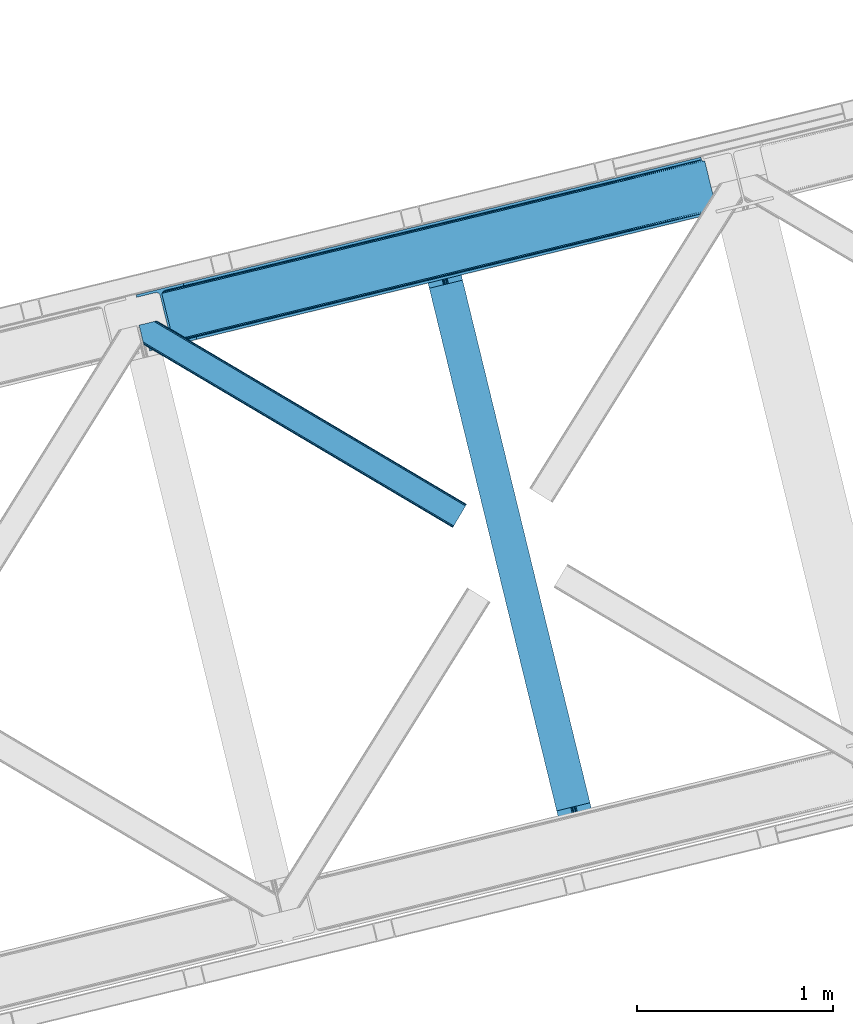
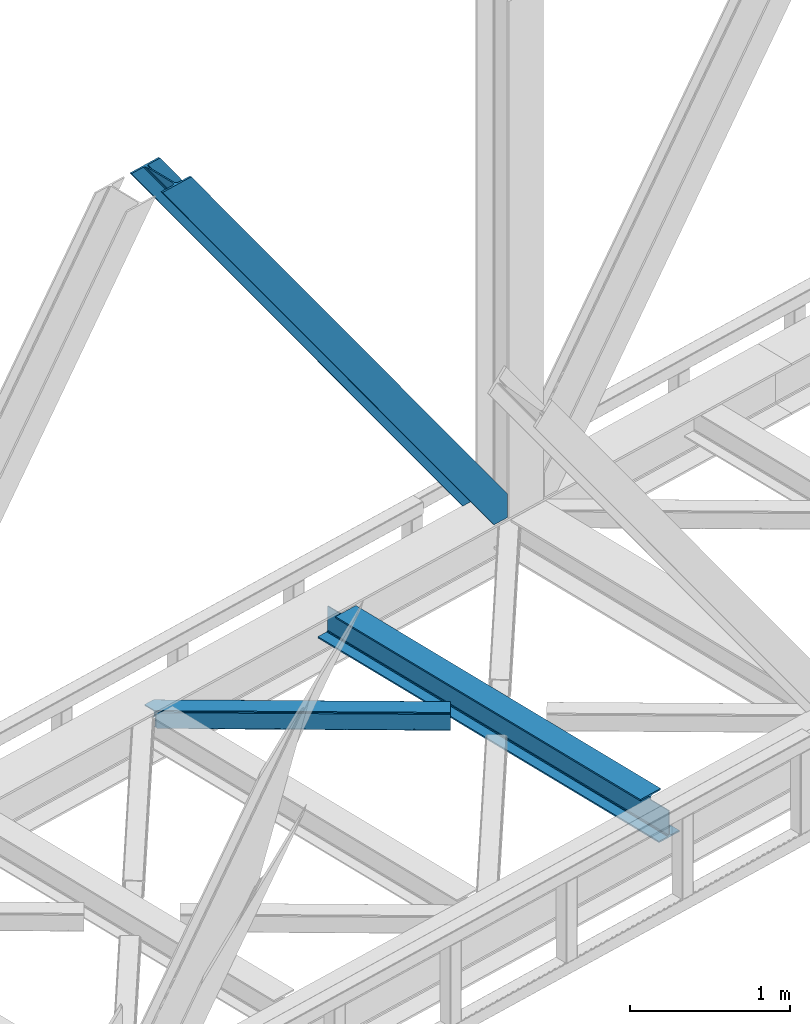
# One storey, part 61 of 92: 2 members, 1 beam.
"""IFC4 building model written with IfcOpenShell, lengths in millimetres."""

from ifc_helpers import new_model, entity, si_unit, converted_unit, derived_unit, direction, frame, origin, place, context, subcontext, project, spatial, triangles, polygons, material, type_object, element, save


model = new_model("IFC4")

# Units and contexts
model_context = context("Model", 3, precision=0.01, world=origin(), true_north=direction((6.12303176911189e-17, 1.0)))
plan_context = context("Plan", 3, precision=0.01, world=origin(), true_north=direction((6.12303176911189e-17, 1.0)))
body_context = subcontext(model_context, "Body", "Model", "MODEL_VIEW")
ifc_project = project(units=[si_unit("LENGTHUNIT", "METRE", prefix="MILLI"), si_unit("AREAUNIT", "SQUARE_METRE"), si_unit("VOLUMEUNIT", "CUBIC_METRE"), converted_unit("PLANEANGLEUNIT", "DEGREE", entity("IfcRatioMeasure", 0.0174532925199433), si_unit("PLANEANGLEUNIT", "RADIAN"), dimensions=[0, 0, 0, 0, 0, 0, 0]), si_unit("MASSUNIT", "GRAM", prefix="KILO"), derived_unit("MASSDENSITYUNIT", [(si_unit("MASSUNIT", "GRAM", prefix="KILO"), 1), (si_unit("LENGTHUNIT", "METRE"), -3)]), derived_unit("MOMENTOFINERTIAUNIT", [(si_unit("LENGTHUNIT", "METRE"), 4)]), si_unit("TIMEUNIT", "SECOND"), si_unit("FREQUENCYUNIT", "HERTZ"), si_unit("THERMODYNAMICTEMPERATUREUNIT", "DEGREE_CELSIUS"), derived_unit("THERMALTRANSMITTANCEUNIT", [(si_unit("MASSUNIT", "GRAM", prefix="KILO"), 1), (si_unit("THERMODYNAMICTEMPERATUREUNIT", "KELVIN"), -1), (si_unit("TIMEUNIT", "SECOND"), -3)]), derived_unit("VOLUMETRICFLOWRATEUNIT", [(si_unit("LENGTHUNIT", "METRE"), 3), (si_unit("TIMEUNIT", "SECOND"), -1)]), derived_unit("MASSFLOWRATEUNIT", [(si_unit("MASSUNIT", "GRAM", prefix="KILO"), 1), (si_unit("TIMEUNIT", "SECOND"), -1)]), derived_unit("ROTATIONALFREQUENCYUNIT", [(si_unit("TIMEUNIT", "SECOND"), -1)]), si_unit("ELECTRICCURRENTUNIT", "AMPERE"), si_unit("ELECTRICVOLTAGEUNIT", "VOLT"), si_unit("POWERUNIT", "WATT"), si_unit("FORCEUNIT", "NEWTON", prefix="KILO"), si_unit("ILLUMINANCEUNIT", "LUX"), si_unit("LUMINOUSFLUXUNIT", "LUMEN"), si_unit("LUMINOUSINTENSITYUNIT", "CANDELA"), derived_unit("USERDEFINED", [(si_unit("MASSUNIT", "GRAM", prefix="KILO"), -1), (si_unit("LENGTHUNIT", "METRE"), -2), (si_unit("TIMEUNIT", "SECOND"), 3), (si_unit("LUMINOUSFLUXUNIT", "LUMEN"), 1)]), derived_unit("LINEARVELOCITYUNIT", [(si_unit("LENGTHUNIT", "METRE"), 1), (si_unit("TIMEUNIT", "SECOND"), -1)]), si_unit("PRESSUREUNIT", "PASCAL"), derived_unit("USERDEFINED", [(si_unit("LENGTHUNIT", "METRE"), -2), (si_unit("MASSUNIT", "GRAM", prefix="KILO"), 1), (si_unit("TIMEUNIT", "SECOND"), -2)]), derived_unit("LINEARFORCEUNIT", [(si_unit("MASSUNIT", "GRAM", prefix="KILO"), 1), (si_unit("LENGTHUNIT", "METRE"), 1), (si_unit("TIMEUNIT", "SECOND"), -2), (si_unit("LENGTHUNIT", "METRE"), -1)]), derived_unit("PLANARFORCEUNIT", [(si_unit("MASSUNIT", "GRAM", prefix="KILO"), 1), (si_unit("LENGTHUNIT", "METRE"), 1), (si_unit("TIMEUNIT", "SECOND"), -2), (si_unit("LENGTHUNIT", "METRE"), -2)])], contexts=[model_context, plan_context])

# Site, building, storey
site_placement = place(None, origin())
site = spatial("IfcSite", under=ifc_project, at=site_placement, CompositionType="ELEMENT")
building_placement = place(site_placement, origin())
building = spatial("IfcBuilding", under=site, at=building_placement, CompositionType="ELEMENT")
storey_placement = place(building_placement, frame((0.0, 0.0, 15900.0)))
storey = spatial("IfcBuildingStorey", under=building, at=storey_placement, Name="05", CompositionType="ELEMENT", Elevation=15900.0)

# Beam
ifc_material = material(Name="Metal painted (White)")
beam_type = type_object("IfcBeamType", PredefinedType="BEAM")
beam_placement = place(storey_placement, frame((-25639.15, 11536.37, 3441.0)))
element("IfcBeam", 1, at=beam_placement, inside=storey, type_object=beam_type, material=ifc_material, ObjectType="Steel Beam", PredefinedType="BEAM", context=body_context, shape_type="Tessellation", body=[
    polygons([(898.85391135252, 41.4445662733125, 11.000000000004), (898.85391135252, 41.4445662733103, 2.16573425859679e-12), (170.021610174757, 3031.3960252037, 2.16573425859679e-12), (170.021610174757, 3031.3960252037, 11.000000000004), (832.788371398898, 25.3403919499699, 11.000000000004), (103.956070221131, 3015.29185088035, 11.000000000004), (826.839621377601, 23.8903211957417, 12.217927479826), (98.007320199834, 3013.84178012613, 12.217927479826), (821.796514621497, 22.6610105689216, 15.6862915010192), (92.964213443734, 3012.61246949931, 15.6862915010192), (818.426818418321, 21.8396114687162, 20.8770650821657), (89.5945172405625, 3011.7910703991, 20.8770650821657), (817.243538468639, 21.5511744621227, 27.0000000000047), (88.4112372908766, 3011.50263339251, 27.0000000000047), (81.6103728838801, 3009.84485074157, 27.0000000000047), (81.6103728838801, 3009.84485074157, 203.000000000006), (88.4112372908766, 3011.50263339251, 203.000000000006), (0.0, 2989.95145893039, 2.16573425859679e-12), (0.0, 2989.95145893039, 10.9999999999997), (66.0655399536172, 3006.05563325373, 11.000000000004), (72.014289974914, 3007.50570400796, 12.2179274798217), (77.057396731014, 3008.73501463478, 15.6862915010192), (80.4270929341986, 3009.55641373499, 20.8770650821657), (817.243538468639, 21.5511744621227, 203.000000000006), (810.442674061647, 19.8933918111897, 203.000000000006), (810.442674061647, 19.8933918111897, 27.0000000000047), (809.259394111961, 19.6049548046006, 20.8770650821657), (805.889697908777, 18.7835557043887, 15.6862915010192), (800.846591152677, 17.5542450775707, 12.2179274798217), (794.89784113138, 16.1041743233447, 11.000000000004), (728.832301177763, 2.16573425859679e-12, 10.9999999999997), (728.832301177763, 2.16573425859679e-12, 2.16573425859679e-12), (777.543778045845, 184.415062601696, 203.069791966819), (125.888966506592, 2857.75452019163, 203.000000000006), (126.111847295742, 2856.8401777572, 203.617301946336), (126.124761540265, 2856.78719778431, 217.000003693143), (777.398574796912, 185.010597404074, 217.000003676718), (777.39944540481, 185.007025963197, 204.00000679514), (770.833476881408, 182.385463974447, 203.006342981529), (770.610629219861, 183.299815969778, 203.617301946336), (770.597714975342, 183.352795942671, 217.000003693143), (119.323901718691, 2855.1293963229, 217.000003676718), (119.323031110798, 2855.13296776378, 204.00000679514), (119.178731521747, 2855.72494066435, 203.076120467494), (119.088102099599, 2856.09673754069, 203.000000000006), (778.582059520948, 185.298194377516, 223.122939328039), (781.951055929627, 186.122464201395, 228.313710402595), (786.993691333638, 187.353708426701, 231.782072735464), (792.942270204354, 188.804481281383, 232.999999602236), (859.007721069869, 204.909021065317, 232.999999283132), (859.006247733431, 204.91506504219, 243.999994005812), (688.984866829519, 163.4695582453, 243.999994827032), (688.986340165957, 163.463514268429, 233.000000104353), (755.05179103148, 179.568054052363, 232.999999785253), (761.00069615981, 181.017488520586, 231.782072861012), (766.044260666937, 182.244921343719, 228.313710479427), (769.414647576681, 183.06348700115, 223.12293937232), (118.140416994651, 2854.84179934946, 223.122939328039), (114.771420585976, 2854.01752952557, 228.313710402599), (109.728785181961, 2852.78628530027, 231.782072735464), (103.780206311245, 2851.33551244559, 232.999999602236), (37.7147554457299, 2835.23097266165, 232.999999283128), (37.7162287821674, 2835.22492868478, 243.999994005812), (207.73760968608, 2876.67043548167, 243.999994827032), (207.736136349642, 2876.67647945855, 233.000000104357), (141.670685484119, 2860.57193967461, 232.999999785253), (135.721780355789, 2859.12250520638, 231.782072861012), (130.678215848667, 2857.89507238325, 228.313710479427), (127.307828938918, 2857.07650672582, 223.12293937232)], [[[1, 2, 3, 4]], [[5, 1, 4, 6]], [[7, 5, 6, 8]], [[9, 7, 8, 10]], [[11, 9, 10, 12]], [[13, 11, 12, 14]], [[15, 16, 17, 14, 12, 10, 8, 6, 4, 3, 18, 19, 20, 21, 22, 23]], [[13, 24, 25, 26, 27, 28, 29, 30, 31, 32, 2, 1, 5, 7, 9, 11]], [[2, 32, 18, 3]], [[32, 31, 19, 18]], [[31, 30, 20, 19]], [[27, 26, 15, 23]], [[28, 27, 23, 22]], [[29, 28, 22, 21]], [[30, 29, 21, 20]], [[33, 24, 13, 14, 17, 34, 35, 36, 37, 38]], [[25, 39, 40, 41, 42, 43, 44, 16, 15, 26]], [[39, 25, 24, 33]], [[45, 34, 17, 16]], [[41, 40, 38, 37, 46, 47, 48, 49, 50, 51, 52, 53, 54, 55, 56, 57]], [[42, 58, 59, 60, 61, 62, 63, 64, 65, 66, 67, 68, 69, 36, 35, 43]], [[46, 37, 36, 69]], [[47, 46, 69, 68]], [[48, 47, 68, 67]], [[49, 48, 67, 66]], [[50, 49, 66, 65]], [[51, 50, 65, 64]], [[52, 51, 64, 63]], [[53, 52, 63, 62]], [[54, 53, 62, 61]], [[55, 54, 61, 60]], [[56, 55, 60, 59]], [[57, 56, 59, 58]], [[41, 57, 58, 42]]], closed=False),
])

# Members
member_type_1 = type_object("IfcMemberType", PredefinedType="BRACE")
member_1_placement = place(storey_placement, frame((-27100.53, 14051.52, 3695.0)))
element("IfcMember", 2, at=member_1_placement, inside=storey, type_object=member_type_1, ObjectType="Steel Vertical Brace", PredefinedType="BRACE", context=body_context, shape_type="Tessellation", body=[
    triangles([(2966.89332275391, 730.999566650391, 0.80925292968459), (2967.55142211914, 730.015905761718, 1.10690917968532), (2966.08174438477, 729.657788085939, 0.0), (2964.18651123047, 737.429406738282, 0.0), (2962.43545532227, 728.768307495118, 8.31577148437282), (2962.43545532227, 728.768307495118, 0.0), (2505.85634765625, 612.606793212892, 658.855133056641), (2511.3606628418, 609.931375122071, 662.301434326171), (2954.04294433594, 717.839904785156, 38.6743835449197), (2954.17084350586, 719.764205932617, 32.1678039550752), (2501.41243286133, 617.533236694337, 656.552947998047), (2958.54266967774, 726.957952880859, 14.8293273925774), (2955.07311401367, 722.241961669923, 26.1867736816384), (2955.64052124024, 723.796517944336, 22.4381652832017), (655.166986083987, 156.054428100586, 3289.34108276367), (649.437103271484, 156.068380737304, 3285.27854003906), (213.879968261721, 48.4865753173835, 3911.00081176758), (205.268865966798, 47.7982452392571, 3911.00081176758), (643.935113525393, 158.743798828125, 3281.83223876953), (197.318188476565, 49.8760253906257, 3911.00081176758), (639.491198730469, 163.67024230957, 3279.53005371094), (191.241815185549, 54.4048187255867, 3911.00081176758), (636.784387207033, 170.100082397461, 3278.7231262207), (187.960620117188, 60.6951324462898, 3911.00081176758), (2954.16154174805, 716.45859375, 50.6410949707024), (2517.08822021485, 609.918585205078, 666.36397705078), (2051.60965576172, 496.452255249023, 1322.10767211914), (2045.87977294922, 496.466207885742, 1318.04512939453), (1586.12876586914, 382.987088012695, 1977.85369262695), (1580.39888305664, 382.999877929688, 1973.78882446289), (1120.64787597656, 269.52075805664, 2633.59738769531), (1114.91799316406, 269.534710693359, 2629.53251953125), (2040.37545776367, 499.140463256836, 1314.598828125), (1574.89689331055, 385.675296020509, 1970.34484863281), (1109.41600341797, 272.208966064452, 2626.08854370117), (2035.93154296875, 504.068069458008, 1312.29896850586), (1570.45065307617, 390.601739501953, 1968.04266357422), (1104.9697631836, 277.136572265625, 2623.78635864258), (2498.70562133789, 623.964239501953, 655.74602050781), (2033.22473144531, 510.497909545898, 1311.48971557617), (1567.74384155274, 397.03274230957, 1967.23341064453), (1102.26527709961, 283.566412353515, 2622.97710571289), (2909.00615844727, 963.801635742188, 0.0), (2443.52526855469, 850.335305786133, 655.74602050781), (1978.04437866211, 736.870138549804, 1311.48971557617), (1512.56348876953, 623.40380859375, 1967.23341064453), (1047.08259887695, 509.937478637696, 2622.97710571289), (581.604034423828, 396.472311401367, 3278.7231262207), (132.780267333987, 287.067361450196, 3911.00081176758), (307.43239746094, 71.2909973144524, 3911.00081176758), (2954.16154174805, 716.45859375, 182.433050537107), (2954.35222778321, 715.476095581054, 0.0), (2954.17084350586, 719.764205932617, 0.0), (2954.35222778321, 715.476095581054, 182.495837402341), (2955.64052124024, 723.796517944336, 0.0), (2958.54266967774, 726.957952880859, 0.0), (2957.19624023438, 703.817504882813, 182.495837402341), (310.511279296876, 58.6603729248054, 3911.00081176758), (2957.19624023438, 703.817504882813, 0.0), (2846.09139404297, 676.735437011719, 0.0), (69.8655029296897, 0.0, 3911.00081176758), (2843.01251220703, 689.364898681641, 0.0), (66.78662109375, 12.6306243896488, 3911.00081176758), (160.336724853518, 35.4350463867195, 3911.00081176758), (2936.56494140625, 712.169320678711, 0.0), (2953.95922851563, 734.936535644532, 0.0), (2953.940625, 727.842782592774, 0.0), (177.733337402344, 58.2022613525387, 3911.00081176758), (177.714733886722, 51.1073455810547, 3911.00081176758), (2950.62919921875, 721.024594116212, 0.0), (174.403308105469, 44.2903198242184, 3911.00081176758), (2944.52724609375, 715.520278930664, 0.0), (168.301354980471, 38.7860046386722, 3911.00081176758), (2898.77887573242, 961.307601928711, 0.0), (122.552984619142, 284.573327636719, 3911.00081176758), (2872.85720214844, 973.517321777344, 0.0), (2881.46830444336, 974.205651855469, 0.0), (105.244738769532, 297.471377563477, 3911.00081176758), (96.6289855957039, 296.781884765625, 3911.00081176758), (2889.4189819336, 972.127871704102, 0.0), (113.193090820314, 295.393597412109, 3911.00081176758), (2895.49768066406, 967.599078369141, 0.0), (119.271789550781, 290.864804077148, 3911.00081176758), (3.07888183593968, 273.978625488282, 3911.00081176758), (2779.30477294922, 950.712899780274, 0.0), (2776.22589111328, 963.342361450195, 0.0), (0.0, 286.608087158203, 3911.00081176758), (142.212249755859, 306.482455444337, 3911.00081176758), (150.174554443362, 309.834576416015, 3911.00081176758), (136.110296630861, 300.979302978516, 3911.00081176758), (132.798870849612, 294.161114501952, 3911.00081176758), (240.648101806641, 345.268460083007, 3911.00081176758), (243.72698364258, 332.638998413086, 3911.00081176758), (2887.33073730469, 990.425592041016, 182.495837402341), (2887.33073730469, 990.425592041016, 0.0), (2890.45612792969, 977.806594848633, 182.433050537107), (2890.17242431641, 978.767001342774, 182.495837402341), (1522.42102661133, 644.333926391602, 1977.85369262695), (591.461572265627, 417.402429199219, 3289.34108276367), (1056.9424621582, 530.867596435546, 2633.59738769531), (1987.90191650391, 757.800256347657, 1322.10767211914), (2453.38280639649, 871.265423583985, 666.36397705078), (2890.45612792969, 977.806594848633, 50.6410949707024), (2890.17242431641, 978.767001342774, 0.0), (2890.986328125, 976.525277709961, 38.6743835449197), (2892.14672241211, 974.999789428712, 33.1630920410134), (2891.98394165039, 974.87537841797, 0.0), (2893.56524047852, 973.138275146484, 26.4425720214822), (2895.14421386719, 971.973229980469, 22.4381652832017), (2903.46463623047, 970.684936523438, 8.31577148437282), (2903.46463623047, 970.684936523438, 0.0), (2899.17652587891, 970.50122680664, 0.0), (2899.17652587891, 970.50122680664, 14.8293273925774), (2895.14421386719, 971.973229980469, 0.0), (2907.11092529297, 971.573254394532, 0.0), (2444.64845581055, 863.710070800782, 658.855133056641), (2442.96948852539, 857.29069519043, 656.552947998047), (2908.45037841797, 970.755862426759, 0.80925292968459), (2908.5829284668, 971.932534790039, 1.10690917968532), (581.048254394533, 403.426538085938, 3279.53005371094), (582.724896240237, 409.847076416016, 3281.83223876953), (586.380487060549, 414.753753662109, 3285.27854003906), (2448.30404663086, 868.616748046876, 662.301434326171), (1977.48859863282, 743.824365234375, 1312.29896850586), (1512.00770874024, 630.358035278321, 1968.04266357422), (1046.52681884766, 516.892868041992, 2623.78635864258), (1979.16756591797, 750.243740844728, 1314.598828125), (1513.68667602539, 636.778573608399, 1970.34484863281), (1048.20578613281, 523.312243652344, 2626.08854370117), (1982.82315673828, 755.151580810547, 1318.04512939453), (1517.34226684571, 641.685250854493, 1973.78882446289), (1051.86137695313, 528.218920898438, 2629.53251953125)], [[1, 2, 3], [3, 4, 1], [2, 5, 6], [6, 3, 2], [7, 8, 9], [9, 10, 7], [11, 12, 5], [5, 1, 11], [11, 7, 13], [13, 14, 11], [14, 12, 11], [15, 16, 17], [18, 17, 16], [16, 19, 18], [20, 18, 19], [19, 21, 20], [22, 20, 21], [21, 23, 22], [24, 22, 23], [5, 2, 1], [10, 13, 7], [25, 9, 8], [8, 26, 25], [26, 8, 27], [28, 27, 8], [27, 28, 29], [30, 29, 28], [29, 30, 31], [32, 31, 30], [31, 32, 15], [16, 15, 32], [8, 7, 33], [33, 28, 8], [28, 33, 34], [34, 30, 28], [30, 34, 35], [35, 32, 30], [32, 35, 16], [19, 16, 35], [7, 11, 36], [36, 33, 7], [33, 36, 37], [37, 34, 33], [34, 37, 38], [38, 35, 34], [35, 38, 21], [21, 19, 35], [1, 4, 11], [39, 11, 4], [11, 39, 36], [40, 36, 39], [36, 40, 37], [41, 37, 40], [37, 41, 42], [42, 38, 37], [38, 42, 23], [23, 21, 38], [4, 43, 44], [45, 39, 44], [41, 40, 45], [41, 45, 46], [44, 39, 4], [45, 40, 39], [42, 41, 46], [46, 47, 42], [47, 48, 23], [49, 24, 48], [47, 23, 42], [48, 24, 23], [50, 51, 29], [29, 31, 50], [31, 15, 50], [17, 50, 15], [27, 29, 51], [51, 25, 26], [26, 27, 51], [52, 9, 25], [52, 53, 10], [10, 9, 52], [25, 51, 54], [54, 52, 25], [14, 53, 55], [53, 14, 13], [10, 53, 13], [56, 12, 55], [14, 55, 12], [6, 5, 56], [12, 56, 5], [57, 54, 58], [54, 51, 50], [50, 58, 54], [57, 59, 52], [52, 54, 57], [58, 60, 57], [58, 61, 60], [60, 59, 57], [62, 60, 63], [61, 63, 60], [63, 64, 62], [65, 62, 64], [66, 67, 68], [69, 68, 67], [67, 70, 69], [71, 69, 70], [70, 72, 71], [73, 71, 72], [72, 65, 73], [64, 73, 65], [74, 66, 75], [68, 75, 66], [76, 77, 78], [78, 79, 76], [77, 80, 81], [81, 78, 77], [80, 82, 83], [83, 81, 80], [82, 74, 75], [75, 83, 82], [79, 84, 85], [85, 76, 79], [86, 85, 87], [84, 87, 85], [75, 68, 49], [71, 73, 18], [64, 61, 17], [63, 61, 64], [73, 64, 17], [68, 69, 22], [69, 71, 20], [81, 88, 78], [87, 79, 89], [79, 78, 89], [87, 84, 79], [81, 83, 90], [83, 75, 91], [49, 68, 24], [17, 18, 73], [22, 69, 20], [18, 20, 71], [22, 24, 68], [58, 17, 61], [58, 50, 17], [89, 78, 88], [90, 83, 91], [49, 91, 75], [90, 88, 81], [89, 92, 87], [92, 89, 93], [92, 86, 87], [86, 92, 94], [95, 86, 94], [96, 97, 93], [97, 94, 92], [92, 93, 97], [98, 96, 93], [93, 99, 100], [99, 93, 89], [100, 98, 93], [96, 98, 101], [101, 102, 96], [103, 96, 102], [97, 104, 94], [95, 94, 104], [104, 105, 106], [96, 103, 97], [104, 97, 103], [103, 105, 104], [107, 108, 109], [107, 106, 108], [110, 111, 112], [112, 113, 110], [113, 112, 114], [114, 109, 113], [109, 114, 107], [106, 107, 104], [53, 70, 55], [76, 86, 95], [85, 86, 76], [77, 76, 95], [104, 80, 77], [77, 95, 104], [104, 107, 80], [60, 65, 59], [52, 72, 70], [65, 72, 59], [60, 62, 65], [70, 53, 52], [52, 59, 72], [43, 66, 74], [82, 112, 74], [80, 114, 82], [80, 107, 114], [82, 114, 112], [111, 43, 74], [112, 111, 74], [43, 111, 115], [4, 66, 43], [56, 66, 6], [55, 70, 67], [67, 66, 56], [56, 55, 67], [4, 6, 66], [3, 6, 4], [116, 113, 109], [117, 118, 113], [113, 116, 117], [109, 108, 116], [118, 119, 110], [110, 113, 118], [48, 120, 91], [91, 49, 48], [120, 121, 90], [90, 91, 120], [121, 122, 88], [88, 90, 121], [122, 99, 89], [89, 88, 122], [105, 103, 123], [102, 123, 103], [106, 116, 108], [116, 106, 105], [123, 116, 105], [43, 118, 117], [117, 44, 43], [44, 117, 124], [124, 45, 44], [45, 124, 125], [125, 46, 45], [46, 125, 47], [126, 47, 125], [47, 126, 48], [120, 48, 126], [117, 116, 124], [127, 124, 116], [124, 127, 125], [128, 125, 127], [125, 128, 126], [129, 126, 128], [126, 129, 120], [121, 120, 129], [116, 123, 127], [130, 127, 123], [127, 130, 128], [131, 128, 130], [128, 131, 129], [132, 129, 131], [129, 132, 122], [122, 121, 129], [123, 102, 101], [101, 130, 123], [130, 101, 98], [98, 131, 130], [131, 98, 100], [100, 132, 131], [132, 100, 99], [99, 122, 132], [110, 119, 111], [115, 111, 119], [119, 118, 115], [43, 115, 118]]),
])
member_type_2 = type_object("IfcMemberType", PredefinedType="BRACE")
member_2_placement = place(storey_placement, frame((-27085.5, 13147.44, 3510.0)))
element("IfcMember", 3, at=member_2_placement, inside=storey, type_object=member_type_2, ObjectType="Steel Horizontal Brace", PredefinedType="BRACE", context=body_context, shape_type="Tessellation", body=[
    triangles([(1674.92102050781, 120.470553588868, 122.500662231447), (1674.92102050781, 120.470553588868, 17.5000946044929), (91.5037170410178, 1057.89356689453, 17.5000946044929), (91.5037170410178, 1057.89356689453, 122.500662231447), (1666.00528564453, 105.412170410156, 139.999594116212), (1669.41670532227, 111.174609375001, 138.667117309571), (76.4813781738303, 1054.23099975586, 138.667117309571), (67.1679931640647, 1051.96137084961, 139.999594116212), (1672.30955200196, 116.060357666016, 134.874325561526), (84.3762451171897, 1056.15530090332, 134.874325561526), (1674.2419921875, 119.324111938477, 129.197927856447), (89.6503417968779, 1057.4412689209, 129.197927856447), (18.7686218261733, 958.59497680664, 139.999594116212), (1612.51552734375, 15.0595458984371, 139.999594116212), (0.0, 1035.58795166016, 139.999594116212), (1603.59746704102, 0.0, 122.500662231447), (1604.27882080078, 1.14644165039135, 129.197927856447), (24.5612915039092, 934.827822875977, 122.500662231447), (24.1194580078154, 936.637014770507, 129.197927856447), (1606.21126098633, 4.41135864257922, 134.874325561526), (22.8637207031279, 941.789025878907, 134.874325561526), (1609.10178222656, 9.29594421386719, 138.667117309571), (20.9847656250022, 949.499020385743, 138.667117309571), (1603.59746704102, 0.0, 17.5000946044929), (24.5612915039092, 934.827822875977, 17.5000946044929), (1674.2419921875, 119.324111938477, 10.8028289794929), (89.5619750976584, 1057.42033996582, 10.8167816162131), (162.736578369142, 1014.02182617187, 10.5005218505867), (1672.30955200196, 116.060357666016, 5.12526855468968), (165.152709960938, 1008.33263854981, 5.12526855468968), (164.09696044922, 1012.66493225098, 9.50058288574292), (163.771398925783, 1012.99281921387, 9.74126586914281), (163.417932128908, 1013.34279785156, 10.0005523681648), (163.066790771485, 1013.69393920898, 10.2586761474631), (89.4712829589844, 1057.39708557129, 10.5005218505867), (1669.41670532227, 111.174609375001, 1.33247680664135), (167.031665039063, 1000.62264404297, 1.33247680664135), (1666.00528564453, 105.412170410156, 0.0), (169.250134277347, 991.52668762207, 0.0), (1612.51552734375, 15.0595458984371, 0.0), (204.010803222656, 848.92608947754, 0.0), (166.88748779297, 996.992633056641, 10.5005218505867), (72.035137939456, 1053.1473449707, 10.5005218505867), (168.582733154297, 994.261404418945, 9.50058288574292), (168.166479492189, 994.934619140626, 9.74591674804833), (167.736273193361, 995.627600097656, 10.0005523681648), (167.306066894533, 996.319418334961, 10.2540252685576), (1668.74465332031, 110.036306762695, 12.1260040283232), (1670.67476806641, 113.301223754883, 17.8035644531265), (79.9183776855498, 1055.06932067871, 17.8035644531265), (1665.85180664063, 105.151721191407, 8.3320495605476), (169.398962402345, 990.918585205078, 8.81690368652562), (74.1164062500029, 1053.65429077148, 12.4271484375022), (171.566271972657, 982.020291137696, 6.99957275390625), (1662.43806152344, 99.388119506837, 6.99957275390625), (1671.35612182617, 114.447665405274, 24.4996673583992), (81.7694274902351, 1055.52045593262, 24.4996673583992), (1671.35612182617, 114.447665405274, 115.501089477541), (81.7694274902351, 1055.52045593262, 115.501089477541), (74.641955566407, 1053.78335266113, 127.87475280762), (66.7494140625022, 1051.85905151367, 131.667544555665), (79.9183776855498, 1055.06932067871, 122.196029663086), (57.4360290527366, 1049.5882598877, 133.000021362306), (0.0, 1035.58795166016, 133.000021362306), (1670.67476806641, 113.301223754883, 122.196029663086), (1668.74465332031, 110.036306762695, 127.87475280762), (1665.85180664063, 105.151721191407, 131.667544555665), (1662.43806152344, 99.388119506837, 133.000021362306), (16.4501586914084, 968.101373291016, 133.000021362306), (1616.08042602539, 21.0824340820309, 133.000021362306), (1616.08042602539, 21.0824340820309, 6.99957275390625), (201.692340087891, 858.433648681641, 6.99957275390625), (1609.77615966797, 10.434246826173, 127.87475280762), (1612.66900634766, 15.3199951171882, 131.667544555665), (1607.16469116211, 6.02405090332104, 115.501089477541), (1607.84371948242, 7.1693298339851, 122.196029663086), (1609.10178222656, 9.29594421386719, 1.33247680664135), (1609.77615966797, 10.434246826173, 12.1260040283232), (1606.21126098633, 4.41135864257922, 5.12526855468968), (1612.66900634766, 15.3199951171882, 8.3320495605476), (1604.27882080078, 1.14644165039135, 10.8028289794929), (1607.16469116211, 6.02405090332104, 24.4996673583992), (1607.84371948242, 7.1693298339851, 17.8035644531265), (18.6686279296882, 959.006579589844, 131.667544555665), (20.547583007814, 951.295422363282, 127.87475280762), (21.8033203125015, 946.143411254883, 122.196029663086), (22.2451538085952, 944.334219360351, 115.501089477541), (22.2451538085952, 944.334219360351, 24.4996673583992), (21.7823913574248, 946.229452514648, 17.8163543701194), (21.7614624023445, 946.318981933595, 17.5000946044929), (203.861975097658, 849.534191894532, 8.81690368652562), (206.226947021485, 839.831295776368, 1.33247680664135), (204.675878906251, 846.191372680665, 9.50058288574292), (208.105902099611, 832.121301269532, 5.12526855468968), (209.161651611328, 827.789007568359, 9.50058288574292), (204.685180664063, 844.928659057618, 10.2075164794951), (204.324737548828, 844.906567382814, 10.3540191650391), (203.966619873048, 844.885638427735, 10.5005218505867), (27.014630126956, 947.468911743164, 12.1260040283232), (28.3494323730483, 948.857199096679, 10.5005218505867), (204.680529785157, 845.560015869141, 9.85404968261719), (32.1375732421875, 931.964044189453, 10.8179443359404), (209.136071777346, 827.584368896485, 9.88311767578125), (208.117529296876, 827.8564453125, 10.5005218505867), (208.803533935548, 827.672735595703, 10.0842681884787), (32.5003417968765, 931.828005981446, 10.5005218505867)], [[1, 2, 3], [3, 4, 1], [5, 6, 7], [7, 8, 5], [6, 9, 10], [10, 7, 6], [9, 11, 12], [12, 10, 9], [11, 1, 4], [4, 12, 11], [5, 13, 14], [13, 5, 8], [15, 13, 8], [16, 17, 18], [19, 18, 17], [17, 20, 19], [21, 19, 20], [20, 22, 21], [23, 21, 22], [22, 14, 23], [13, 23, 14], [24, 16, 18], [18, 25, 24], [26, 27, 3], [27, 26, 28], [26, 29, 30], [30, 31, 26], [26, 32, 33], [32, 26, 31], [26, 34, 28], [34, 26, 33], [28, 35, 27], [29, 36, 37], [37, 30, 29], [36, 38, 39], [39, 37, 36], [3, 2, 26], [38, 40, 41], [41, 39, 38], [28, 42, 35], [43, 35, 42], [31, 44, 45], [45, 32, 31], [32, 45, 46], [46, 33, 32], [33, 46, 47], [47, 34, 33], [34, 47, 42], [42, 28, 34], [48, 49, 50], [45, 51, 46], [45, 44, 51], [42, 47, 51], [47, 46, 51], [44, 52, 51], [48, 53, 42], [42, 51, 48], [53, 43, 42], [51, 52, 54], [54, 55, 51], [50, 53, 48], [49, 56, 57], [57, 50, 49], [56, 58, 57], [59, 57, 58], [60, 61, 7], [10, 60, 7], [10, 12, 62], [60, 10, 62], [62, 12, 4], [61, 8, 7], [15, 63, 64], [15, 8, 63], [61, 63, 8], [62, 4, 59], [57, 3, 50], [4, 57, 59], [3, 27, 50], [4, 3, 57], [35, 50, 27], [35, 53, 50], [35, 43, 53], [58, 65, 59], [62, 59, 65], [65, 66, 62], [60, 62, 66], [66, 67, 60], [61, 60, 67], [67, 68, 61], [63, 61, 68], [68, 69, 63], [68, 70, 69], [69, 64, 63], [71, 55, 72], [54, 72, 55], [11, 66, 65], [58, 2, 1], [11, 65, 1], [11, 9, 66], [65, 58, 1], [66, 9, 6], [68, 5, 14], [5, 67, 6], [67, 5, 68], [67, 66, 6], [26, 48, 29], [56, 2, 58], [2, 49, 26], [49, 2, 56], [26, 49, 48], [38, 55, 40], [36, 29, 48], [48, 51, 36], [51, 55, 38], [38, 36, 51], [73, 22, 20], [14, 70, 68], [14, 74, 70], [74, 14, 22], [73, 74, 22], [75, 16, 24], [17, 76, 73], [20, 17, 73], [76, 17, 16], [75, 76, 16], [77, 78, 79], [40, 55, 71], [71, 80, 40], [80, 78, 77], [77, 40, 80], [81, 79, 78], [24, 82, 75], [83, 24, 81], [24, 83, 82], [83, 81, 78], [70, 74, 84], [84, 69, 70], [74, 73, 85], [85, 84, 74], [73, 76, 86], [86, 85, 73], [76, 75, 87], [87, 86, 76], [75, 82, 88], [88, 87, 75], [86, 87, 18], [18, 19, 86], [21, 86, 19], [86, 21, 85], [18, 88, 25], [89, 90, 25], [25, 88, 89], [87, 88, 18], [84, 23, 13], [15, 69, 13], [64, 69, 15], [84, 85, 23], [23, 85, 21], [69, 84, 13], [44, 30, 37], [39, 44, 37], [54, 52, 39], [54, 39, 72], [30, 44, 31], [39, 52, 44], [72, 41, 91], [41, 92, 93], [41, 72, 39], [94, 93, 92], [41, 93, 91], [94, 95, 93], [83, 89, 88], [71, 72, 91], [78, 96, 97], [97, 98, 78], [98, 99, 78], [98, 100, 99], [80, 91, 93], [93, 78, 80], [78, 93, 101], [101, 96, 78], [83, 78, 99], [99, 90, 83], [90, 89, 83], [91, 80, 71], [88, 82, 83], [24, 25, 102], [79, 103, 95], [81, 102, 104], [104, 79, 81], [104, 105, 79], [95, 94, 79], [40, 77, 92], [92, 41, 40], [77, 79, 94], [94, 92, 77], [106, 81, 24], [99, 106, 25], [99, 100, 106], [25, 90, 99], [98, 104, 106], [106, 100, 98]]),
])

save(model, "model.ifc")
